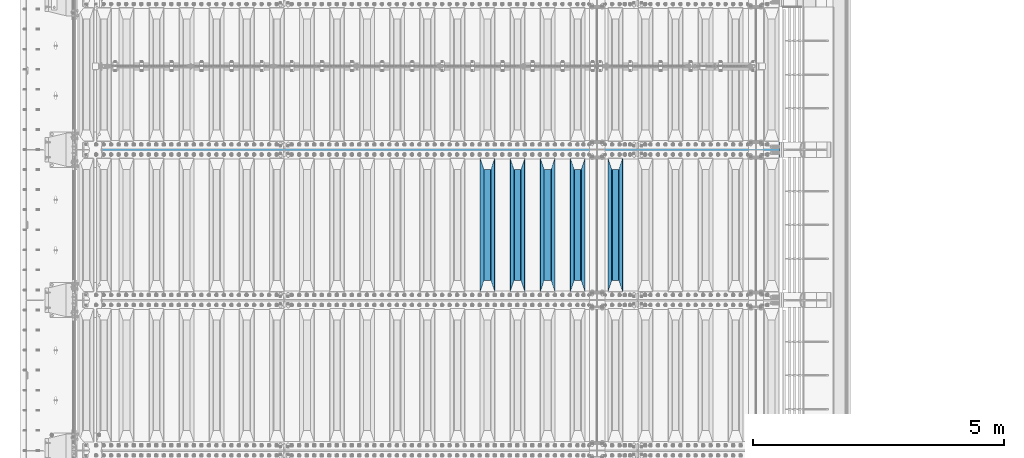
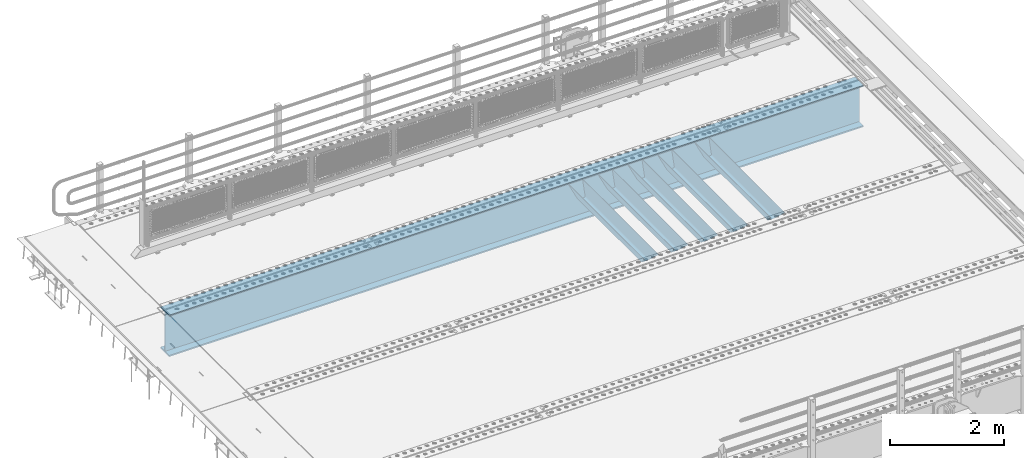
# One storey, part 120 of 240: 6 beams.
"""IFC2X3 building model written with IfcOpenShell, lengths in millimetres."""

from ifc_helpers import new_model, si_unit, frame, origin_with_axes, place, context, subcontext, project, spatial, faceted_brep, material, type_object, element, save


model = new_model("IFC2X3")

# Units and contexts
model_context = context("Model", 3, precision=1e-05, world=origin_with_axes())
body_context = subcontext(model_context, "Body", "Model", "MODEL_VIEW")
ifc_project = project(units=[si_unit("LENGTHUNIT", "METRE", prefix="MILLI"), si_unit("AREAUNIT", "SQUARE_METRE"), si_unit("VOLUMEUNIT", "CUBIC_METRE"), si_unit("MASSUNIT", "GRAM", prefix="KILO"), si_unit("TIMEUNIT", "SECOND"), si_unit("PLANEANGLEUNIT", "RADIAN"), si_unit("SOLIDANGLEUNIT", "STERADIAN"), si_unit("THERMODYNAMICTEMPERATUREUNIT", "DEGREE_CELSIUS"), si_unit("LUMINOUSINTENSITYUNIT", "LUMEN")], contexts=[model_context])

# Site, building, storey
site_placement = place(None, origin_with_axes())
site = spatial("IfcSite", under=ifc_project, at=site_placement, CompositionType="ELEMENT")
building_placement = place(site_placement, origin_with_axes())
building = spatial("IfcBuilding", under=site, at=building_placement, Name="Standard", CompositionType="ELEMENT")
storey_placement = place(building_placement, origin_with_axes())
storey = spatial("IfcBuildingStorey", under=building, at=storey_placement, Name="Undefined", CompositionType="ELEMENT", Elevation=0.0)

# Beams
ifc_material = material(Name="STEEL/S355N")
beam_type_1 = type_object("IfcBeamType", PredefinedType="NOTDEFINED")
beam_1_placement = place(storey_placement, frame((53200.0, 30175.0, -115.0), z_axis=(0.0, 0.0, 1.0), x_axis=(0.0, 1.0, 0.0)))
element("IfcBeam", 1, at=beam_1_placement, inside=storey, type_object=beam_type_1, material=ifc_material, context=body_context, shape_type="Brep", body=[
    faceted_brep([(0.0, 150.0, 115.0), (0.0, 143.690000000002, 115.0), (2650.00000000297, 143.690000000002, 115.0), (2650.00000000297, 150.0, 115.0), (2650.00000000297, 142.059565218406, 110.000000003094), (2650.00000000297, 148.369565218403, 110.000000003094), (2441.90079219209, -80.1103600731149, -98.0992078077845), (2437.7588105432, -77.5672621345584, -102.241189456673), (2434.06523489747, -74.4080125315522, -105.934765102404), (2430.9108609509, -70.7102721255724, -109.089139048974), (2428.37322971128, -66.5649389910031, -111.626770288588), (2426.51472138055, -62.0739139532889, -113.485278619323), (2425.38102192092, -57.3475956567636, -114.618978078955), (2424.99999999987, -52.5021667386536, -115.0), (2424.99999999987, 52.5021667386536, -115.0), (2425.38102192092, 57.3475956567636, -114.618978078955), (2426.51472138055, 62.0739139532889, -113.485278619323), (2428.37322971128, 66.5649389910031, -111.626770288588), (2430.9108609509, 70.7102721255724, -109.089139048974), (2434.06523489747, 74.4080125315522, -105.934765102404), (2437.7588105432, 77.5672621345584, -102.241189456673), (2441.90079219209, 80.1103600731149, -98.0992078077846), (2446.38936140512, 81.9747917625791, -93.6106385947584), (2448.2494850041, 76.2713538057287, -91.7505149957729), (2444.62967112263, 74.76777986261, -95.3703288772456), (2441.28936334127, 72.7168944282894, -98.710636658607), (2438.31067330439, 70.1691124903809, -101.689326695487), (2435.76682334748, 67.1870637758839, -104.233176652398), (2433.72034654134, 63.8440531834931, -106.279653458539), (2432.22154950042, 60.2222587982324, -107.778450499454), (2431.30727574265, 56.4107117849126, -108.692724257221), (2430.99999999987, 52.5031078186876, -109.0), (2430.99999999987, -52.5031078186876, -109.0), (2431.30727574265, -56.4107117849126, -108.692724257221), (2432.22154950042, -60.2222587982324, -107.778450499454), (2433.72034654134, -63.8440531834931, -106.279653458539), (2435.76682334748, -67.1870637758839, -104.233176652398), (2438.31067330439, -70.1691124903809, -101.689326695487), (2441.28936334127, -72.7168944282894, -98.7106366586071), (2444.62967112263, -74.76777986261, -95.3703288772457), (2448.2494850041, -76.2713538057287, -91.7505149957729), (2650.00000000297, -142.059565218406, 110.000000003094), (2650.00000000297, -148.369565218403, 110.000000003094), (2446.38936140512, -81.9747917625791, -93.6106385947584), (2650.00000000297, -143.690000000002, 115.0), (2650.00000000297, -150.0, 115.0), (0.0, -143.690000000002, 115.0), (0.0, -150.0, 115.0), (0.0, -148.369565218258, 110.000000002667), (203.610638597427, -81.9747917625791, -93.6106385947584), (208.09920781045, -80.1103600731149, -98.0992078077845), (212.241189459342, -77.5672621345584, -102.241189456673), (215.93476510507, -74.4080125315522, -105.934765102404), (219.089139051641, -70.7102721255724, -109.089139048974), (221.626770291256, -66.5649389910031, -111.626770288588), (223.485278621989, -62.0739139532889, -113.485278619323), (224.618978081624, -57.3475956567636, -114.618978078955), (225.000000002663, -52.5021667386536, -115.0), (225.000000002663, 52.5021667386536, -115.0), (224.618978081624, 57.3475956567636, -114.618978078955), (223.485278621989, 62.0739139532889, -113.485278619323), (221.626770291256, 66.5649389910031, -111.626770288588), (219.089139051641, 70.7102721255724, -109.089139048974), (215.93476510507, 74.4080125315522, -105.934765102404), (212.241189459342, 77.5672621345584, -102.241189456673), (208.09920781045, 80.1103600731149, -98.0992078077846), (203.610638597427, 81.9747917625791, -93.6106385947584), (0.0, 148.369565218258, 110.000000002667), (0.0, 142.05956521826, 110.000000002667), (201.750514998439, 76.2713538057287, -91.7505149957729), (205.370328879908, 74.76777986261, -95.3703288772456), (208.710636661275, 72.7168944282894, -98.710636658607), (211.689326698153, 70.1691124903809, -101.689326695487), (214.233176655063, 67.1870637758839, -104.233176652398), (216.279653461206, 63.8440531834931, -106.279653458539), (217.778450502123, 60.2222587982324, -107.778450499454), (218.692724259887, 56.4107117849126, -108.692724257221), (219.000000002667, 52.5031078186876, -109.0), (219.000000002667, -52.5031078186876, -109.0), (218.692724259887, -56.4107117849126, -108.692724257221), (217.778450502123, -60.2222587982324, -107.778450499454), (216.279653461206, -63.8440531834931, -106.279653458539), (214.233176655063, -67.1870637758839, -104.233176652398), (211.689326698153, -70.1691124903809, -101.689326695487), (208.710636661275, -72.7168944282894, -98.7106366586071), (205.370328879915, -74.76777986261, -95.3703288772457), (201.750514998439, -76.2713538057287, -91.7505149957729), (0.0, -142.05956521826, 110.000000002667)], [[[0, 1, 2, 3]], [[3, 2, 4, 5]], [[6, 7, 8, 9, 10, 11, 12, 13, 14, 15, 16, 17, 18, 19, 20, 21, 22, 5, 4, 23, 24, 25, 26, 27, 28, 29, 30, 31, 32, 33, 34, 35, 36, 37, 38, 39, 40, 41, 42, 43]], [[44, 45, 42, 41]], [[46, 47, 45, 44]], [[43, 42, 45, 47, 48, 49]], [[6, 43, 49, 50]], [[7, 6, 50, 51]], [[8, 7, 51, 52]], [[9, 8, 52, 53]], [[10, 9, 53, 54]], [[11, 10, 54, 55]], [[12, 11, 55, 56]], [[13, 12, 56, 57]], [[14, 13, 57, 58]], [[15, 14, 58, 59]], [[16, 15, 59, 60]], [[17, 16, 60, 61]], [[18, 17, 61, 62]], [[19, 18, 62, 63]], [[20, 19, 63, 64]], [[21, 20, 64, 65]], [[22, 21, 65, 66]], [[0, 3, 5, 22, 66, 67]], [[1, 0, 67, 68]], [[23, 4, 2, 1, 68, 69]], [[24, 23, 69, 70]], [[25, 24, 70, 71]], [[26, 25, 71, 72]], [[27, 26, 72, 73]], [[28, 27, 73, 74]], [[29, 28, 74, 75]], [[30, 29, 75, 76]], [[31, 30, 76, 77]], [[32, 31, 77, 78]], [[33, 32, 78, 79]], [[34, 33, 79, 80]], [[35, 34, 80, 81]], [[36, 35, 81, 82]], [[37, 36, 82, 83]], [[38, 37, 83, 84]], [[39, 38, 84, 85]], [[40, 39, 85, 86]], [[46, 44, 41, 40, 86, 87]], [[47, 46, 87, 48]], [[86, 85, 84, 83, 82, 81, 80, 79, 78, 77, 76, 75, 74, 73, 72, 71, 70, 69, 68, 67, 66, 65, 64, 63, 62, 61, 60, 59, 58, 57, 56, 55, 54, 53, 52, 51, 50, 49, 48, 87]]]),
])
beam_2_placement = place(storey_placement, frame((52450.0, 30175.0, -115.0), z_axis=(0.0, 0.0, 1.0), x_axis=(0.0, 1.0, 0.0)))
element("IfcBeam", 2, at=beam_2_placement, inside=storey, type_object=beam_type_1, material=ifc_material, context=body_context, shape_type="Brep", body=[
    faceted_brep([(0.0, 150.0, 115.0), (0.0, 143.690000000002, 115.0), (2650.00000000297, 143.690000000002, 115.0), (2650.00000000297, 150.0, 115.0), (2650.00000000297, 142.059565218406, 110.000000003094), (2650.00000000297, 148.369565218403, 110.000000003094), (2441.90079219209, -80.1103600731149, -98.0992078077845), (2437.7588105432, -77.5672621345584, -102.241189456673), (2434.06523489747, -74.4080125315522, -105.934765102404), (2430.9108609509, -70.7102721255724, -109.089139048974), (2428.37322971128, -66.5649389910031, -111.626770288588), (2426.51472138055, -62.0739139532889, -113.485278619323), (2425.38102192092, -57.3475956567636, -114.618978078955), (2424.99999999987, -52.5021667386536, -115.0), (2424.99999999987, 52.5021667386536, -115.0), (2425.38102192092, 57.3475956567636, -114.618978078955), (2426.51472138055, 62.0739139532889, -113.485278619323), (2428.37322971128, 66.5649389910031, -111.626770288588), (2430.9108609509, 70.7102721255724, -109.089139048974), (2434.06523489747, 74.4080125315522, -105.934765102404), (2437.7588105432, 77.5672621345584, -102.241189456673), (2441.90079219209, 80.1103600731149, -98.0992078077846), (2446.38936140512, 81.9747917625791, -93.6106385947584), (2448.2494850041, 76.2713538057287, -91.7505149957729), (2444.62967112263, 74.76777986261, -95.3703288772456), (2441.28936334127, 72.7168944282894, -98.710636658607), (2438.31067330439, 70.1691124903809, -101.689326695487), (2435.76682334748, 67.1870637758839, -104.233176652398), (2433.72034654134, 63.8440531834931, -106.279653458539), (2432.22154950042, 60.2222587982324, -107.778450499454), (2431.30727574265, 56.4107117849126, -108.692724257221), (2430.99999999987, 52.5031078186876, -109.0), (2430.99999999987, -52.5031078186876, -109.0), (2431.30727574265, -56.4107117849126, -108.692724257221), (2432.22154950042, -60.2222587982324, -107.778450499454), (2433.72034654134, -63.8440531834931, -106.279653458539), (2435.76682334748, -67.1870637758839, -104.233176652398), (2438.31067330439, -70.1691124903809, -101.689326695487), (2441.28936334127, -72.7168944282894, -98.7106366586071), (2444.62967112263, -74.76777986261, -95.3703288772457), (2448.2494850041, -76.2713538057287, -91.7505149957729), (2650.00000000297, -142.059565218406, 110.000000003094), (2650.00000000297, -148.369565218403, 110.000000003094), (2446.38936140512, -81.9747917625791, -93.6106385947584), (2650.00000000297, -143.690000000002, 115.0), (2650.00000000297, -150.0, 115.0), (0.0, -143.690000000002, 115.0), (0.0, -150.0, 115.0), (0.0, -148.369565218258, 110.000000002667), (203.610638597427, -81.9747917625791, -93.6106385947584), (208.09920781045, -80.1103600731149, -98.0992078077845), (212.241189459342, -77.5672621345584, -102.241189456673), (215.93476510507, -74.4080125315522, -105.934765102404), (219.089139051641, -70.7102721255724, -109.089139048974), (221.626770291256, -66.5649389910031, -111.626770288588), (223.485278621989, -62.0739139532889, -113.485278619323), (224.618978081624, -57.3475956567636, -114.618978078955), (225.000000002663, -52.5021667386536, -115.0), (225.000000002663, 52.5021667386536, -115.0), (224.618978081624, 57.3475956567636, -114.618978078955), (223.485278621989, 62.0739139532889, -113.485278619323), (221.626770291256, 66.5649389910031, -111.626770288588), (219.089139051641, 70.7102721255724, -109.089139048974), (215.93476510507, 74.4080125315522, -105.934765102404), (212.241189459342, 77.5672621345584, -102.241189456673), (208.09920781045, 80.1103600731149, -98.0992078077846), (203.610638597427, 81.9747917625791, -93.6106385947584), (0.0, 148.369565218258, 110.000000002667), (0.0, 142.05956521826, 110.000000002667), (201.750514998439, 76.2713538057287, -91.7505149957729), (205.370328879908, 74.76777986261, -95.3703288772456), (208.710636661275, 72.7168944282894, -98.710636658607), (211.689326698153, 70.1691124903809, -101.689326695487), (214.233176655063, 67.1870637758839, -104.233176652398), (216.279653461206, 63.8440531834931, -106.279653458539), (217.778450502123, 60.2222587982324, -107.778450499454), (218.692724259887, 56.4107117849126, -108.692724257221), (219.000000002667, 52.5031078186876, -109.0), (219.000000002667, -52.5031078186876, -109.0), (218.692724259887, -56.4107117849126, -108.692724257221), (217.778450502123, -60.2222587982324, -107.778450499454), (216.279653461206, -63.8440531834931, -106.279653458539), (214.233176655063, -67.1870637758839, -104.233176652398), (211.689326698153, -70.1691124903809, -101.689326695487), (208.710636661275, -72.7168944282894, -98.7106366586071), (205.370328879915, -74.76777986261, -95.3703288772457), (201.750514998439, -76.2713538057287, -91.7505149957729), (0.0, -142.05956521826, 110.000000002667)], [[[0, 1, 2, 3]], [[3, 2, 4, 5]], [[6, 7, 8, 9, 10, 11, 12, 13, 14, 15, 16, 17, 18, 19, 20, 21, 22, 5, 4, 23, 24, 25, 26, 27, 28, 29, 30, 31, 32, 33, 34, 35, 36, 37, 38, 39, 40, 41, 42, 43]], [[44, 45, 42, 41]], [[46, 47, 45, 44]], [[43, 42, 45, 47, 48, 49]], [[6, 43, 49, 50]], [[7, 6, 50, 51]], [[8, 7, 51, 52]], [[9, 8, 52, 53]], [[10, 9, 53, 54]], [[11, 10, 54, 55]], [[12, 11, 55, 56]], [[13, 12, 56, 57]], [[14, 13, 57, 58]], [[15, 14, 58, 59]], [[16, 15, 59, 60]], [[17, 16, 60, 61]], [[18, 17, 61, 62]], [[19, 18, 62, 63]], [[20, 19, 63, 64]], [[21, 20, 64, 65]], [[22, 21, 65, 66]], [[0, 3, 5, 22, 66, 67]], [[1, 0, 67, 68]], [[23, 4, 2, 1, 68, 69]], [[24, 23, 69, 70]], [[25, 24, 70, 71]], [[26, 25, 71, 72]], [[27, 26, 72, 73]], [[28, 27, 73, 74]], [[29, 28, 74, 75]], [[30, 29, 75, 76]], [[31, 30, 76, 77]], [[32, 31, 77, 78]], [[33, 32, 78, 79]], [[34, 33, 79, 80]], [[35, 34, 80, 81]], [[36, 35, 81, 82]], [[37, 36, 82, 83]], [[38, 37, 83, 84]], [[39, 38, 84, 85]], [[40, 39, 85, 86]], [[46, 44, 41, 40, 86, 87]], [[47, 46, 87, 48]], [[86, 85, 84, 83, 82, 81, 80, 79, 78, 77, 76, 75, 74, 73, 72, 71, 70, 69, 68, 67, 66, 65, 64, 63, 62, 61, 60, 59, 58, 57, 56, 55, 54, 53, 52, 51, 50, 49, 48, 87]]]),
])
beam_3_placement = place(storey_placement, frame((51850.0, 30175.0, -115.0), z_axis=(0.0, 0.0, 1.0), x_axis=(0.0, 1.0, 0.0)))
element("IfcBeam", 3, at=beam_3_placement, inside=storey, type_object=beam_type_1, material=ifc_material, context=body_context, shape_type="Brep", body=[
    faceted_brep([(0.0, 150.0, 115.0), (0.0, 143.690000000002, 115.0), (2650.00000000297, 143.690000000002, 115.0), (2650.00000000297, 150.0, 115.0), (2650.00000000297, 142.059565218406, 110.000000003094), (2650.00000000297, 148.369565218403, 110.000000003094), (2441.90079219209, -80.1103600731149, -98.0992078077845), (2437.7588105432, -77.5672621345584, -102.241189456673), (2434.06523489747, -74.4080125315522, -105.934765102404), (2430.9108609509, -70.7102721255724, -109.089139048974), (2428.37322971128, -66.5649389910031, -111.626770288588), (2426.51472138055, -62.0739139532889, -113.485278619323), (2425.38102192092, -57.3475956567636, -114.618978078955), (2424.99999999987, -52.5021667386536, -115.0), (2424.99999999987, 52.5021667386536, -115.0), (2425.38102192092, 57.3475956567636, -114.618978078955), (2426.51472138055, 62.0739139532889, -113.485278619323), (2428.37322971128, 66.5649389910031, -111.626770288588), (2430.9108609509, 70.7102721255724, -109.089139048974), (2434.06523489747, 74.4080125315522, -105.934765102404), (2437.7588105432, 77.5672621345584, -102.241189456673), (2441.90079219209, 80.1103600731149, -98.0992078077846), (2446.38936140512, 81.9747917625791, -93.6106385947584), (2448.2494850041, 76.2713538057287, -91.7505149957729), (2444.62967112263, 74.76777986261, -95.3703288772456), (2441.28936334127, 72.7168944282894, -98.710636658607), (2438.31067330439, 70.1691124903809, -101.689326695487), (2435.76682334748, 67.1870637758839, -104.233176652398), (2433.72034654134, 63.8440531834931, -106.279653458539), (2432.22154950042, 60.2222587982324, -107.778450499454), (2431.30727574265, 56.4107117849126, -108.692724257221), (2430.99999999987, 52.5031078186876, -109.0), (2430.99999999987, -52.5031078186876, -109.0), (2431.30727574265, -56.4107117849126, -108.692724257221), (2432.22154950042, -60.2222587982324, -107.778450499454), (2433.72034654134, -63.8440531834931, -106.279653458539), (2435.76682334748, -67.1870637758839, -104.233176652398), (2438.31067330439, -70.1691124903809, -101.689326695487), (2441.28936334127, -72.7168944282894, -98.7106366586071), (2444.62967112263, -74.76777986261, -95.3703288772457), (2448.2494850041, -76.2713538057287, -91.7505149957729), (2650.00000000297, -142.059565218406, 110.000000003094), (2650.00000000297, -148.369565218403, 110.000000003094), (2446.38936140512, -81.9747917625791, -93.6106385947584), (2650.00000000297, -143.690000000002, 115.0), (2650.00000000297, -150.0, 115.0), (0.0, -143.690000000002, 115.0), (0.0, -150.0, 115.0), (0.0, -148.369565218258, 110.000000002667), (203.610638597427, -81.9747917625791, -93.6106385947584), (208.09920781045, -80.1103600731149, -98.0992078077845), (212.241189459342, -77.5672621345584, -102.241189456673), (215.93476510507, -74.4080125315522, -105.934765102404), (219.089139051641, -70.7102721255724, -109.089139048974), (221.626770291256, -66.5649389910031, -111.626770288588), (223.485278621989, -62.0739139532889, -113.485278619323), (224.618978081624, -57.3475956567636, -114.618978078955), (225.000000002663, -52.5021667386536, -115.0), (225.000000002663, 52.5021667386536, -115.0), (224.618978081624, 57.3475956567636, -114.618978078955), (223.485278621989, 62.0739139532889, -113.485278619323), (221.626770291256, 66.5649389910031, -111.626770288588), (219.089139051641, 70.7102721255724, -109.089139048974), (215.93476510507, 74.4080125315522, -105.934765102404), (212.241189459342, 77.5672621345584, -102.241189456673), (208.09920781045, 80.1103600731149, -98.0992078077846), (203.610638597427, 81.9747917625791, -93.6106385947584), (0.0, 148.369565218258, 110.000000002667), (0.0, 142.05956521826, 110.000000002667), (201.750514998439, 76.2713538057287, -91.7505149957729), (205.370328879908, 74.76777986261, -95.3703288772456), (208.710636661275, 72.7168944282894, -98.710636658607), (211.689326698153, 70.1691124903809, -101.689326695487), (214.233176655063, 67.1870637758839, -104.233176652398), (216.279653461206, 63.8440531834931, -106.279653458539), (217.778450502123, 60.2222587982324, -107.778450499454), (218.692724259887, 56.4107117849126, -108.692724257221), (219.000000002667, 52.5031078186876, -109.0), (219.000000002667, -52.5031078186876, -109.0), (218.692724259887, -56.4107117849126, -108.692724257221), (217.778450502123, -60.2222587982324, -107.778450499454), (216.279653461206, -63.8440531834931, -106.279653458539), (214.233176655063, -67.1870637758839, -104.233176652398), (211.689326698153, -70.1691124903809, -101.689326695487), (208.710636661275, -72.7168944282894, -98.7106366586071), (205.370328879915, -74.76777986261, -95.3703288772457), (201.750514998439, -76.2713538057287, -91.7505149957729), (0.0, -142.05956521826, 110.000000002667)], [[[0, 1, 2, 3]], [[3, 2, 4, 5]], [[6, 7, 8, 9, 10, 11, 12, 13, 14, 15, 16, 17, 18, 19, 20, 21, 22, 5, 4, 23, 24, 25, 26, 27, 28, 29, 30, 31, 32, 33, 34, 35, 36, 37, 38, 39, 40, 41, 42, 43]], [[44, 45, 42, 41]], [[46, 47, 45, 44]], [[43, 42, 45, 47, 48, 49]], [[6, 43, 49, 50]], [[7, 6, 50, 51]], [[8, 7, 51, 52]], [[9, 8, 52, 53]], [[10, 9, 53, 54]], [[11, 10, 54, 55]], [[12, 11, 55, 56]], [[13, 12, 56, 57]], [[14, 13, 57, 58]], [[15, 14, 58, 59]], [[16, 15, 59, 60]], [[17, 16, 60, 61]], [[18, 17, 61, 62]], [[19, 18, 62, 63]], [[20, 19, 63, 64]], [[21, 20, 64, 65]], [[22, 21, 65, 66]], [[0, 3, 5, 22, 66, 67]], [[1, 0, 67, 68]], [[23, 4, 2, 1, 68, 69]], [[24, 23, 69, 70]], [[25, 24, 70, 71]], [[26, 25, 71, 72]], [[27, 26, 72, 73]], [[28, 27, 73, 74]], [[29, 28, 74, 75]], [[30, 29, 75, 76]], [[31, 30, 76, 77]], [[32, 31, 77, 78]], [[33, 32, 78, 79]], [[34, 33, 79, 80]], [[35, 34, 80, 81]], [[36, 35, 81, 82]], [[37, 36, 82, 83]], [[38, 37, 83, 84]], [[39, 38, 84, 85]], [[40, 39, 85, 86]], [[46, 44, 41, 40, 86, 87]], [[47, 46, 87, 48]], [[86, 85, 84, 83, 82, 81, 80, 79, 78, 77, 76, 75, 74, 73, 72, 71, 70, 69, 68, 67, 66, 65, 64, 63, 62, 61, 60, 59, 58, 57, 56, 55, 54, 53, 52, 51, 50, 49, 48, 87]]]),
])
beam_4_placement = place(storey_placement, frame((51250.0, 30175.0, -115.0), z_axis=(0.0, 0.0, 1.0), x_axis=(0.0, 1.0, 0.0)))
element("IfcBeam", 4, at=beam_4_placement, inside=storey, type_object=beam_type_1, material=ifc_material, context=body_context, shape_type="Brep", body=[
    faceted_brep([(0.0, 150.0, 115.0), (0.0, 143.690000000002, 115.0), (2650.00000000297, 143.690000000002, 115.0), (2650.00000000297, 150.0, 115.0), (2650.00000000297, 142.059565218406, 110.000000003094), (2650.00000000297, 148.369565218403, 110.000000003094), (2441.90079219209, -80.1103600731149, -98.0992078077845), (2437.7588105432, -77.5672621345584, -102.241189456673), (2434.06523489747, -74.4080125315522, -105.934765102404), (2430.9108609509, -70.7102721255724, -109.089139048974), (2428.37322971128, -66.5649389910031, -111.626770288588), (2426.51472138055, -62.0739139532889, -113.485278619323), (2425.38102192092, -57.3475956567636, -114.618978078955), (2424.99999999987, -52.5021667386536, -115.0), (2424.99999999987, 52.5021667386536, -115.0), (2425.38102192092, 57.3475956567636, -114.618978078955), (2426.51472138055, 62.0739139532889, -113.485278619323), (2428.37322971128, 66.5649389910031, -111.626770288588), (2430.9108609509, 70.7102721255724, -109.089139048974), (2434.06523489747, 74.4080125315522, -105.934765102404), (2437.7588105432, 77.5672621345584, -102.241189456673), (2441.90079219209, 80.1103600731149, -98.0992078077846), (2446.38936140512, 81.9747917625791, -93.6106385947584), (2448.2494850041, 76.2713538057287, -91.7505149957729), (2444.62967112263, 74.76777986261, -95.3703288772456), (2441.28936334127, 72.7168944282894, -98.710636658607), (2438.31067330439, 70.1691124903809, -101.689326695487), (2435.76682334748, 67.1870637758839, -104.233176652398), (2433.72034654134, 63.8440531834931, -106.279653458539), (2432.22154950042, 60.2222587982324, -107.778450499454), (2431.30727574265, 56.4107117849126, -108.692724257221), (2430.99999999987, 52.5031078186876, -109.0), (2430.99999999987, -52.5031078186876, -109.0), (2431.30727574265, -56.4107117849126, -108.692724257221), (2432.22154950042, -60.2222587982324, -107.778450499454), (2433.72034654134, -63.8440531834931, -106.279653458539), (2435.76682334748, -67.1870637758839, -104.233176652398), (2438.31067330439, -70.1691124903809, -101.689326695487), (2441.28936334127, -72.7168944282894, -98.7106366586071), (2444.62967112263, -74.76777986261, -95.3703288772457), (2448.2494850041, -76.2713538057287, -91.7505149957729), (2650.00000000297, -142.059565218406, 110.000000003094), (2650.00000000297, -148.369565218403, 110.000000003094), (2446.38936140512, -81.9747917625791, -93.6106385947584), (2650.00000000297, -143.690000000002, 115.0), (2650.00000000297, -150.0, 115.0), (0.0, -143.690000000002, 115.0), (0.0, -150.0, 115.0), (0.0, -148.369565218258, 110.000000002667), (203.610638597427, -81.9747917625791, -93.6106385947584), (208.09920781045, -80.1103600731149, -98.0992078077845), (212.241189459342, -77.5672621345584, -102.241189456673), (215.93476510507, -74.4080125315522, -105.934765102404), (219.089139051641, -70.7102721255724, -109.089139048974), (221.626770291256, -66.5649389910031, -111.626770288588), (223.485278621989, -62.0739139532889, -113.485278619323), (224.618978081624, -57.3475956567636, -114.618978078955), (225.000000002663, -52.5021667386536, -115.0), (225.000000002663, 52.5021667386536, -115.0), (224.618978081624, 57.3475956567636, -114.618978078955), (223.485278621989, 62.0739139532889, -113.485278619323), (221.626770291256, 66.5649389910031, -111.626770288588), (219.089139051641, 70.7102721255724, -109.089139048974), (215.93476510507, 74.4080125315522, -105.934765102404), (212.241189459342, 77.5672621345584, -102.241189456673), (208.09920781045, 80.1103600731149, -98.0992078077846), (203.610638597427, 81.9747917625791, -93.6106385947584), (0.0, 148.369565218258, 110.000000002667), (0.0, 142.05956521826, 110.000000002667), (201.750514998439, 76.2713538057287, -91.7505149957729), (205.370328879908, 74.76777986261, -95.3703288772456), (208.710636661275, 72.7168944282894, -98.710636658607), (211.689326698153, 70.1691124903809, -101.689326695487), (214.233176655063, 67.1870637758839, -104.233176652398), (216.279653461206, 63.8440531834931, -106.279653458539), (217.778450502123, 60.2222587982324, -107.778450499454), (218.692724259887, 56.4107117849126, -108.692724257221), (219.000000002667, 52.5031078186876, -109.0), (219.000000002667, -52.5031078186876, -109.0), (218.692724259887, -56.4107117849126, -108.692724257221), (217.778450502123, -60.2222587982324, -107.778450499454), (216.279653461206, -63.8440531834931, -106.279653458539), (214.233176655063, -67.1870637758839, -104.233176652398), (211.689326698153, -70.1691124903809, -101.689326695487), (208.710636661275, -72.7168944282894, -98.7106366586071), (205.370328879915, -74.76777986261, -95.3703288772457), (201.750514998439, -76.2713538057287, -91.7505149957729), (0.0, -142.05956521826, 110.000000002667)], [[[0, 1, 2, 3]], [[3, 2, 4, 5]], [[6, 7, 8, 9, 10, 11, 12, 13, 14, 15, 16, 17, 18, 19, 20, 21, 22, 5, 4, 23, 24, 25, 26, 27, 28, 29, 30, 31, 32, 33, 34, 35, 36, 37, 38, 39, 40, 41, 42, 43]], [[44, 45, 42, 41]], [[46, 47, 45, 44]], [[43, 42, 45, 47, 48, 49]], [[6, 43, 49, 50]], [[7, 6, 50, 51]], [[8, 7, 51, 52]], [[9, 8, 52, 53]], [[10, 9, 53, 54]], [[11, 10, 54, 55]], [[12, 11, 55, 56]], [[13, 12, 56, 57]], [[14, 13, 57, 58]], [[15, 14, 58, 59]], [[16, 15, 59, 60]], [[17, 16, 60, 61]], [[18, 17, 61, 62]], [[19, 18, 62, 63]], [[20, 19, 63, 64]], [[21, 20, 64, 65]], [[22, 21, 65, 66]], [[0, 3, 5, 22, 66, 67]], [[1, 0, 67, 68]], [[23, 4, 2, 1, 68, 69]], [[24, 23, 69, 70]], [[25, 24, 70, 71]], [[26, 25, 71, 72]], [[27, 26, 72, 73]], [[28, 27, 73, 74]], [[29, 28, 74, 75]], [[30, 29, 75, 76]], [[31, 30, 76, 77]], [[32, 31, 77, 78]], [[33, 32, 78, 79]], [[34, 33, 79, 80]], [[35, 34, 80, 81]], [[36, 35, 81, 82]], [[37, 36, 82, 83]], [[38, 37, 83, 84]], [[39, 38, 84, 85]], [[40, 39, 85, 86]], [[46, 44, 41, 40, 86, 87]], [[47, 46, 87, 48]], [[86, 85, 84, 83, 82, 81, 80, 79, 78, 77, 76, 75, 74, 73, 72, 71, 70, 69, 68, 67, 66, 65, 64, 63, 62, 61, 60, 59, 58, 57, 56, 55, 54, 53, 52, 51, 50, 49, 48, 87]]]),
])
beam_5_placement = place(storey_placement, frame((50650.0, 30175.0, -115.0), z_axis=(0.0, 0.0, 1.0), x_axis=(0.0, 1.0, 0.0)))
element("IfcBeam", 5, at=beam_5_placement, inside=storey, type_object=beam_type_1, material=ifc_material, context=body_context, shape_type="Brep", body=[
    faceted_brep([(0.0, 150.0, 115.0), (0.0, 143.690000000002, 115.0), (2650.00000000297, 143.690000000002, 115.0), (2650.00000000297, 150.0, 115.0), (2650.00000000297, 142.059565218406, 110.000000003094), (2650.00000000297, 148.369565218403, 110.000000003094), (2441.90079219209, -80.1103600731149, -98.0992078077845), (2437.7588105432, -77.5672621345584, -102.241189456673), (2434.06523489747, -74.4080125315522, -105.934765102404), (2430.9108609509, -70.7102721255724, -109.089139048974), (2428.37322971128, -66.5649389910031, -111.626770288588), (2426.51472138055, -62.0739139532889, -113.485278619323), (2425.38102192092, -57.3475956567636, -114.618978078955), (2424.99999999987, -52.5021667386536, -115.0), (2424.99999999987, 52.5021667386536, -115.0), (2425.38102192092, 57.3475956567636, -114.618978078955), (2426.51472138055, 62.0739139532889, -113.485278619323), (2428.37322971128, 66.5649389910031, -111.626770288588), (2430.9108609509, 70.7102721255724, -109.089139048974), (2434.06523489747, 74.4080125315522, -105.934765102404), (2437.7588105432, 77.5672621345584, -102.241189456673), (2441.90079219209, 80.1103600731149, -98.0992078077846), (2446.38936140512, 81.9747917625791, -93.6106385947584), (2448.2494850041, 76.2713538057287, -91.7505149957729), (2444.62967112263, 74.76777986261, -95.3703288772456), (2441.28936334127, 72.7168944282894, -98.710636658607), (2438.31067330439, 70.1691124903809, -101.689326695487), (2435.76682334748, 67.1870637758839, -104.233176652398), (2433.72034654134, 63.8440531834931, -106.279653458539), (2432.22154950042, 60.2222587982324, -107.778450499454), (2431.30727574265, 56.4107117849126, -108.692724257221), (2430.99999999987, 52.5031078186876, -109.0), (2430.99999999987, -52.5031078186876, -109.0), (2431.30727574265, -56.4107117849126, -108.692724257221), (2432.22154950042, -60.2222587982324, -107.778450499454), (2433.72034654134, -63.8440531834931, -106.279653458539), (2435.76682334748, -67.1870637758839, -104.233176652398), (2438.31067330439, -70.1691124903809, -101.689326695487), (2441.28936334127, -72.7168944282894, -98.7106366586071), (2444.62967112263, -74.76777986261, -95.3703288772457), (2448.2494850041, -76.2713538057287, -91.7505149957729), (2650.00000000297, -142.059565218406, 110.000000003094), (2650.00000000297, -148.369565218403, 110.000000003094), (2446.38936140512, -81.9747917625791, -93.6106385947584), (2650.00000000297, -143.690000000002, 115.0), (2650.00000000297, -150.0, 115.0), (0.0, -143.690000000002, 115.0), (0.0, -150.0, 115.0), (0.0, -148.369565218258, 110.000000002667), (203.610638597427, -81.9747917625791, -93.6106385947584), (208.09920781045, -80.1103600731149, -98.0992078077845), (212.241189459342, -77.5672621345584, -102.241189456673), (215.93476510507, -74.4080125315522, -105.934765102404), (219.089139051641, -70.7102721255724, -109.089139048974), (221.626770291256, -66.5649389910031, -111.626770288588), (223.485278621989, -62.0739139532889, -113.485278619323), (224.618978081624, -57.3475956567636, -114.618978078955), (225.000000002663, -52.5021667386536, -115.0), (225.000000002663, 52.5021667386536, -115.0), (224.618978081624, 57.3475956567636, -114.618978078955), (223.485278621989, 62.0739139532889, -113.485278619323), (221.626770291256, 66.5649389910031, -111.626770288588), (219.089139051641, 70.7102721255724, -109.089139048974), (215.93476510507, 74.4080125315522, -105.934765102404), (212.241189459342, 77.5672621345584, -102.241189456673), (208.09920781045, 80.1103600731149, -98.0992078077846), (203.610638597427, 81.9747917625791, -93.6106385947584), (0.0, 148.369565218258, 110.000000002667), (0.0, 142.05956521826, 110.000000002667), (201.750514998439, 76.2713538057287, -91.7505149957729), (205.370328879908, 74.76777986261, -95.3703288772456), (208.710636661275, 72.7168944282894, -98.710636658607), (211.689326698153, 70.1691124903809, -101.689326695487), (214.233176655063, 67.1870637758839, -104.233176652398), (216.279653461206, 63.8440531834931, -106.279653458539), (217.778450502123, 60.2222587982324, -107.778450499454), (218.692724259887, 56.4107117849126, -108.692724257221), (219.000000002667, 52.5031078186876, -109.0), (219.000000002667, -52.5031078186876, -109.0), (218.692724259887, -56.4107117849126, -108.692724257221), (217.778450502123, -60.2222587982324, -107.778450499454), (216.279653461206, -63.8440531834931, -106.279653458539), (214.233176655063, -67.1870637758839, -104.233176652398), (211.689326698153, -70.1691124903809, -101.689326695487), (208.710636661275, -72.7168944282894, -98.7106366586071), (205.370328879915, -74.76777986261, -95.3703288772457), (201.750514998439, -76.2713538057287, -91.7505149957729), (0.0, -142.05956521826, 110.000000002667)], [[[0, 1, 2, 3]], [[3, 2, 4, 5]], [[6, 7, 8, 9, 10, 11, 12, 13, 14, 15, 16, 17, 18, 19, 20, 21, 22, 5, 4, 23, 24, 25, 26, 27, 28, 29, 30, 31, 32, 33, 34, 35, 36, 37, 38, 39, 40, 41, 42, 43]], [[44, 45, 42, 41]], [[46, 47, 45, 44]], [[43, 42, 45, 47, 48, 49]], [[6, 43, 49, 50]], [[7, 6, 50, 51]], [[8, 7, 51, 52]], [[9, 8, 52, 53]], [[10, 9, 53, 54]], [[11, 10, 54, 55]], [[12, 11, 55, 56]], [[13, 12, 56, 57]], [[14, 13, 57, 58]], [[15, 14, 58, 59]], [[16, 15, 59, 60]], [[17, 16, 60, 61]], [[18, 17, 61, 62]], [[19, 18, 62, 63]], [[20, 19, 63, 64]], [[21, 20, 64, 65]], [[22, 21, 65, 66]], [[0, 3, 5, 22, 66, 67]], [[1, 0, 67, 68]], [[23, 4, 2, 1, 68, 69]], [[24, 23, 69, 70]], [[25, 24, 70, 71]], [[26, 25, 71, 72]], [[27, 26, 72, 73]], [[28, 27, 73, 74]], [[29, 28, 74, 75]], [[30, 29, 75, 76]], [[31, 30, 76, 77]], [[32, 31, 77, 78]], [[33, 32, 78, 79]], [[34, 33, 79, 80]], [[35, 34, 80, 81]], [[36, 35, 81, 82]], [[37, 36, 82, 83]], [[38, 37, 83, 84]], [[39, 38, 84, 85]], [[40, 39, 85, 86]], [[46, 44, 41, 40, 86, 87]], [[47, 46, 87, 48]], [[86, 85, 84, 83, 82, 81, 80, 79, 78, 77, 76, 75, 74, 73, 72, 71, 70, 69, 68, 67, 66, 65, 64, 63, 62, 61, 60, 59, 58, 57, 56, 55, 54, 53, 52, 51, 50, 49, 48, 87]]]),
])
beam_type_2 = type_object("IfcBeamType", Name="HEA900", PredefinedType="NOTDEFINED")
beam_6_placement = place(storey_placement, frame((42460.0, 33000.0, -445.0), z_axis=(0.0, 0.0, 1.0), x_axis=(1.0, 0.0, 0.0)))
element("IfcBeam", 6, at=beam_6_placement, inside=storey, type_object=beam_type_2, material=ifc_material, ObjectType="HEA900", context=body_context, shape_type="Brep", body=[
    faceted_brep([(0.0, 150.0, -445.0), (0.0, 150.0, -415.0), (14017.0, 150.0, -415.0), (14017.0, 150.0, -445.0), (0.0, 8.0, -415.0), (14017.0, 8.0, -415.0), (0.0, 8.0, 415.0), (14017.0, 8.0, 415.0), (0.0, 150.0, 415.0), (14017.0, 150.0, 415.0), (0.0, 150.0, 445.0), (14017.0, 150.0, 445.0), (0.0, -150.0, 445.0), (14017.0, -150.0, 445.0), (0.0, -150.0, 415.0), (14017.0, -150.0, 415.0), (0.0, -8.0, 415.0), (14017.0, -8.0, 415.0), (0.0, -8.0, -415.0), (14017.0, -8.0, -415.0), (0.0, -150.0, -415.0), (14017.0, -150.0, -415.0), (0.0, -150.0, -445.0), (14017.0, -150.0, -445.0)], [[[0, 1, 2, 3]], [[1, 4, 5, 2]], [[4, 6, 7, 5]], [[6, 8, 9, 7]], [[8, 10, 11, 9]], [[10, 12, 13, 11]], [[12, 14, 15, 13]], [[14, 16, 17, 15]], [[16, 18, 19, 17]], [[18, 20, 21, 19]], [[20, 22, 23, 21]], [[22, 0, 3, 23]], [[5, 7, 9, 11, 13, 15, 17, 19, 21, 23, 3, 2]], [[22, 20, 18, 16, 14, 12, 10, 8, 6, 4, 1, 0]]]),
])

save(model, "model.ifc")
